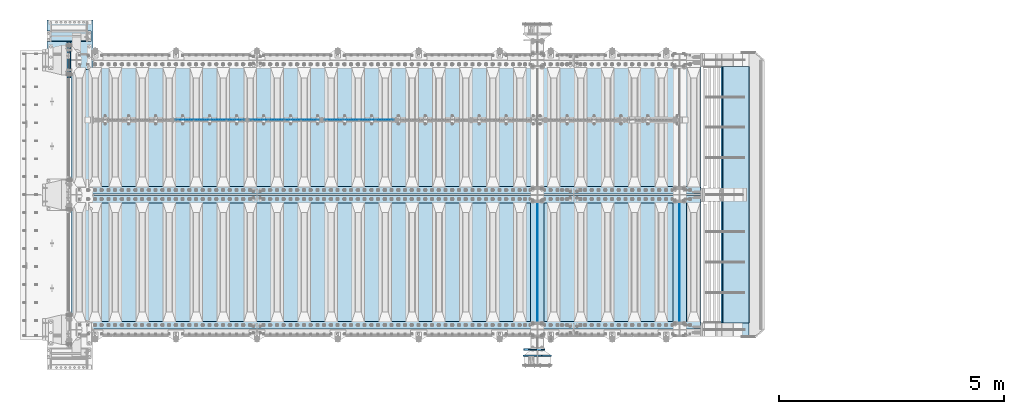
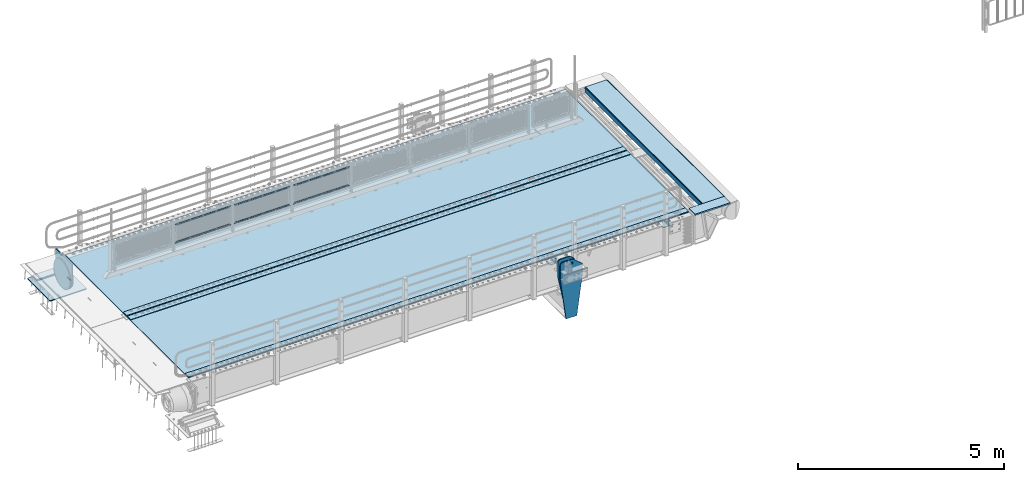
# One storey, part 152 of 193: 24 plates.
"""IFC2X3 building model written with IfcOpenShell, lengths in millimetres."""

from ifc_helpers import new_model, si_unit, frame, origin_with_axes, place, context, subcontext, project, spatial, faceted_brep, material, type_object, element, save


model = new_model("IFC2X3")

# Units and contexts
model_context = context("Model", 3, precision=1e-05, world=origin_with_axes())
body_context = subcontext(model_context, "Body", "Model", "MODEL_VIEW")
ifc_project = project(units=[si_unit("LENGTHUNIT", "METRE", prefix="MILLI"), si_unit("AREAUNIT", "SQUARE_METRE"), si_unit("VOLUMEUNIT", "CUBIC_METRE"), si_unit("MASSUNIT", "GRAM", prefix="KILO"), si_unit("TIMEUNIT", "SECOND"), si_unit("PLANEANGLEUNIT", "RADIAN"), si_unit("SOLIDANGLEUNIT", "STERADIAN"), si_unit("THERMODYNAMICTEMPERATUREUNIT", "DEGREE_CELSIUS"), si_unit("LUMINOUSINTENSITYUNIT", "LUMEN")], contexts=[model_context])

# Site, building, storey
site_placement = place(None, origin_with_axes())
site = spatial("IfcSite", under=ifc_project, at=site_placement, CompositionType="ELEMENT")
building_placement = place(site_placement, origin_with_axes())
building = spatial("IfcBuilding", under=site, at=building_placement, Name="Standard", CompositionType="ELEMENT")
storey_placement = place(building_placement, origin_with_axes())
storey = spatial("IfcBuildingStorey", under=building, at=storey_placement, Name="Undefined", CompositionType="ELEMENT", Elevation=0.0)

# Plates
ifc_material_1 = material(Name="STEEL/S355N")
plate_type_1 = type_object("IfcPlateType", PredefinedType="NOTDEFINED")
plate_1_placement = place(storey_placement, frame((-31899.9999999193, 23559.9999999953, -945.000018212691), z_axis=(-0.901283188008789, 0.0, 0.433230441004224), x_axis=(-0.433230441004221, 0.0, -0.90128318800879)))
element("IfcPlate", 1, at=plate_1_placement, inside=storey, type_object=plate_type_1, material=ifc_material_1, context=body_context, shape_type="Brep", body=[
    faceted_brep([(22.094240398199, -15.0000000000109, 175.22583880938), (22.094240398199, 14.9999999999854, 175.22583880938), (270.848403445216, 15.0, 55.654235574897), (270.848403445216, -15.0, 55.654235574897), (15.5957837831356, -15.0000000000109, 161.706590989248), (15.5957837831356, 14.9999999999854, 161.706590989248), (264.349946032446, -15.0, 42.1349881382121), (264.349946032446, 15.0, 42.1349881382121), (244.096420288086, -15.0, 6.91215973347425e-11), (244.096420288086, 15.0, 6.91215973347425e-11), (0.0, -15.0, 0.0), (0.0, 15.0, 0.0), (-976.801818847653, -15.0, 469.530853271488), (-976.801818847653, 15.0, 469.530853271488), (-1005.61098604241, -15.0, 584.572481266798), (-1005.61098604241, 15.0, 584.572481266794), (-1008.62084772102, -15.0, 603.379189822288), (-1008.62084772102, 15.0, 603.379189822292), (-1008.34151554686, -14.9999999999964, 622.423179098525), (-1008.34151554686, 15.0000000000036, 622.423179098525), (-1004.78138982914, -15.0, 641.133500175365), (-1004.78138982914, 15.0, 641.133500175365), (-998.047132923919, -15.0, 658.949304871177), (-998.047132923919, 15.0, 658.949304871177), (-903.393050005916, -15.0, 855.865691431824), (-903.393050005918, 15.0, 855.865691431824), (-891.965949445463, -15.0, 873.34628110176), (-891.965949445461, 15.0, 873.346281101767), (-876.403907448048, -15.0, 887.273681838968), (-876.403907448048, 15.0, 887.273681838968), (-857.767451990536, -15.0, 896.698763822915), (-857.767451990536, 15.0, 896.698763822918), (-837.326627351673, -14.9999999999964, 900.979222969672), (-837.326627351673, 15.0000000000036, 900.979222969676), (-816.474442649767, -15.0, 899.823352915755), (-816.474442649764, 15.0, 899.823352915759), (-796.631940525467, -14.9999999999964, 893.309924335023), (-796.631940525465, 15.0000000000036, 893.309924335026), (-427.105804443356, -14.9999999999964, 715.685363769535), (-427.105804443354, 15.0000000000036, 715.685363769539), (138.633743286133, -15.0, 288.410614013668), (138.633743286133, 15.0, 288.410614013668), (291.101928710936, -15.0, 97.7892227172815), (291.101928710936, 15.0, 97.7892227172815), (-886.324025694375, -15.0000000000182, 572.182288694501), (-886.324025694375, 14.9999999999818, 572.182288694501), (-901.776420284152, 14.9999999999818, 569.989346058286), (-901.776420284152, -15.0000000000182, 569.989346058286), (-872.8870774196, -15.0000000000182, 580.121678911954), (-872.8870774196, 14.9999999999818, 580.121678911954), (-863.511229028423, -15.0000000000182, 592.598816520771), (-863.511229028423, 14.9999999999818, 592.598816520771), (-859.623868446119, -15.0000000000182, 607.714170425563), (-859.623868446119, 14.9999999999818, 607.714170425563), (-861.816811082334, -15.0000000000182, 623.166565015341), (-861.816811082334, 14.9999999999818, 623.166565015341), (-869.756201299781, -15.0000000000182, 636.603513290116), (-869.756201299781, 14.9999999999818, 636.603513290116), (-882.233338908603, -15.0000000000182, 645.979361681293), (-882.233338908603, 14.9999999999818, 645.979361681293), (-897.348692813393, -15.0000000000182, 649.8667222636), (-897.348692813393, 14.9999999999818, 649.8667222636), (-912.80108740317, -15.0000000000182, 647.673779627385), (-912.80108740317, 14.9999999999818, 647.673779627385), (-926.238035677947, -15.0000000000182, 639.734389409932), (-926.238035677947, 14.9999999999818, 639.734389409932), (-935.613884069126, -15.0000000000182, 627.257251801111), (-935.613884069126, 14.9999999999818, 627.257251801111), (-939.501244651428, -15.0000000000182, 612.141897896323), (-939.501244651428, 14.9999999999818, 612.141897896323), (-937.308302015212, -15.0000000000182, 596.689503306545), (-937.308302015212, 14.9999999999818, 596.689503306545), (-929.368911797765, -15.0000000000182, 583.25255503177), (-929.368911797765, 14.9999999999818, 583.25255503177), (-916.891774188942, -15.0000000000182, 573.876706640593), (-916.891774188942, 14.9999999999818, 573.876706640593), (-844.133640442278, 15.0, 583.284362107021), (-843.85829752604, 15.0, 588.251621237385), (-847.175983297808, 15.0, 591.958700695603), (-852.143242428174, 15.0, 592.234043611839), (-855.850321886393, 15.0, 588.916357840073), (-856.125664802632, 15.0, 583.949098709705), (-852.807979030862, 15.0, 580.242019251487), (-847.840719900496, 15.0, 579.966676335251), (-847.840719900496, -15.0, 579.966676335251), (-852.807979030862, -15.0, 580.242019251487), (-844.133640442278, -15.0, 583.284362107021), (-843.85829752604, -15.0, 588.251621237385), (-847.175983297808, -15.0, 591.958700695603), (-852.143242428174, -15.0, 592.234043611839), (-855.850321886393, -15.0, 588.916357840073), (-856.125664802632, -15.0, 583.949098709705)], [[[0, 1, 2, 3]], [[4, 5, 1, 0]], [[6, 7, 5, 4]], [[8, 9, 7, 6]], [[8, 10, 11, 9]], [[10, 12, 13, 11]], [[12, 14, 15, 13]], [[14, 16, 17, 15]], [[16, 18, 19, 17]], [[18, 20, 21, 19]], [[20, 22, 23, 21]], [[22, 24, 25, 23]], [[24, 26, 27, 25]], [[26, 28, 29, 27]], [[28, 30, 31, 29]], [[30, 32, 33, 31]], [[32, 34, 35, 33]], [[34, 36, 37, 35]], [[36, 38, 39, 37]], [[38, 40, 41, 39]], [[40, 42, 43, 41]], [[43, 42, 3, 2]], [[44, 45, 46, 47]], [[48, 49, 45, 44]], [[50, 51, 49, 48]], [[52, 53, 51, 50]], [[54, 55, 53, 52]], [[56, 57, 55, 54]], [[58, 59, 57, 56]], [[60, 61, 59, 58]], [[62, 63, 61, 60]], [[64, 65, 63, 62]], [[66, 67, 65, 64]], [[68, 69, 67, 66]], [[70, 71, 69, 68]], [[72, 73, 71, 70]], [[74, 75, 73, 72]], [[47, 46, 75, 74]], [[9, 11, 13, 15, 17, 19, 21, 23, 25, 27, 29, 31, 33, 35, 37, 39, 41, 43, 2, 1, 5, 7], [76, 77, 78, 79, 80, 81, 82, 83], [45, 49, 51, 53, 55, 57, 59, 61, 63, 65, 67, 69, 71, 73, 75, 46]], [[84, 83, 82, 85]], [[86, 76, 83, 84]], [[87, 77, 76, 86]], [[88, 78, 77, 87]], [[89, 79, 78, 88]], [[90, 80, 79, 89]], [[91, 81, 80, 90]], [[85, 82, 81, 91]], [[3, 42, 40, 38, 36, 34, 32, 30, 28, 26, 24, 22, 20, 18, 16, 14, 12, 10, 8, 6, 4, 0], [90, 89, 88, 87, 86, 84, 85, 91], [70, 68, 66, 64, 62, 60, 58, 56, 54, 52, 50, 48, 44, 47, 74, 72]]]),
])
plate_type_2 = type_object("IfcPlateType", PredefinedType="NOTDEFINED")
for number, where, z_axis, x_axis in (
    (2, (-28895.0, 26825.0, 0.0), (0.0, 0.0, -1.0), (0.0, -1.0, 0.0)),
    (3, (-32060.0, 26825.0, 0.0), (0.0, 0.0, -1.0), (0.0, -1.0, 0.0)),
):
    element("IfcPlate", number, at=place(storey_placement, frame(where, z_axis=z_axis, x_axis=x_axis)), inside=storey, type_object=plate_type_2, material=ifc_material_1, context=body_context, shape_type="Brep", body=[
        faceted_brep([(0.0, -5.0, 0.0), (0.0, -5.0, 336.0), (0.0, 5.0, 336.0), (0.0, 5.0, 0.0), (2650.0, -5.0, 336.0), (2650.0, 5.0, 336.0), (2650.0, -5.0, 0.0), (2650.0, 5.0, 0.0)], [[[0, 1, 2, 3]], [[1, 4, 5, 2]], [[4, 6, 7, 5]], [[6, 0, 3, 7]], [[5, 7, 3, 2]], [[6, 4, 1, 0]]]),
    ])
plate_type_3 = type_object("IfcPlateType", PredefinedType="NOTDEFINED")
for number, where, z_axis, x_axis in (
    (4, (-29045.0, 24175.0, -343.0), (0.0, 1.0, 0.0), (1.0, 0.0, 0.0)),
    (5, (-32210.0, 24175.0, -343.0), (0.0, 1.0, 0.0), (1.0, 0.0, 0.0)),
):
    element("IfcPlate", number, at=place(storey_placement, frame(where, z_axis=z_axis, x_axis=x_axis)), inside=storey, type_object=plate_type_3, material=ifc_material_1, context=body_context, shape_type="Brep", body=[
        faceted_brep([(0.0, -7.0, 0.0), (0.0, -7.0, 2650.0), (0.0, 7.0, 2650.0), (0.0, 7.0, 0.0), (300.0, -7.0, 2650.0), (300.0, 7.0, 2650.0), (300.0, -7.0, 0.0), (300.0, 7.0, 0.0)], [[[0, 1, 2, 3]], [[1, 4, 5, 2]], [[4, 6, 7, 5]], [[6, 0, 3, 7]], [[5, 7, 3, 2]], [[6, 4, 1, 0]]]),
    ])
ifc_material_2 = material(Name="Misc_Undefined")
plate_type_4 = type_object("IfcPlateType", PredefinedType="NOTDEFINED")
plate_2_placement = place(storey_placement, frame((-36801.4949882696, 28670.5, 351.520303374641), z_axis=(0.0, 0.0, 1.0), x_axis=(1.0, 0.0, 0.0)))
element("IfcPlate", 6, at=plate_2_placement, inside=storey, type_object=plate_type_4, material=ifc_material_2, context=body_context, shape_type="Brep", body=[
    faceted_brep([(0.0, -1.49999999999636, 3.63797880709171e-12), (35.0002975463831, -1.5, 34.9996948242187), (35.0002975463831, 1.5, 34.9996948242187), (0.0, 1.50000000000364, 7.27595761418343e-12), (1515.99035644531, -1.5, 34.9999923706054), (1515.99035644531, 1.5, 34.9999923706054), (1550.98999023437, -1.5, 4.43037606601138e-09), (1550.98999023437, 1.5, 4.43037606601138e-09)], [[[0, 1, 2, 3]], [[1, 4, 5, 2]], [[4, 6, 7, 5]], [[6, 0, 3, 7]], [[5, 7, 3, 2]], [[6, 4, 1, 0]]]),
])
plate_3_placement = place(storey_placement, frame((-35250.4999998124, 28670.5, 914.520000175701), z_axis=(-0.707103624179499, 0.0, 0.707109938179501), x_axis=(-0.707109938179501, 0.0, -0.707103624179499)))
element("IfcPlate", 7, at=plate_3_placement, inside=storey, type_object=plate_type_4, material=ifc_material_2, context=body_context, shape_type="Brep", body=[
    faceted_brep([(0.0, -1.49999999999636, 3.63797880709171e-12), (1096.7275390625, -1.5, 1096.7177734375), (1096.7275390625, 1.5, 1096.7177734375), (0.0, 1.50000000000364, 7.27595761418343e-12), (1096.72045898438, -1.5, 1047.21337890625), (1096.72045898438, 1.5, 1047.21337890625), (49.4976959228552, -1.5, -1.01863406598568e-10), (49.4976959228552, 1.5, -1.01863406598568e-10)], [[[0, 1, 2, 3]], [[1, 4, 5, 2]], [[4, 6, 7, 5]], [[6, 0, 3, 7]], [[5, 7, 3, 2]], [[6, 4, 1, 0]]]),
])
plate_4_placement = place(storey_placement, frame((-38459.4949882696, 28670.5, 351.520303374641), z_axis=(0.0, 0.0, 1.0), x_axis=(1.0, 0.0, 0.0)))
element("IfcPlate", 8, at=plate_4_placement, inside=storey, type_object=plate_type_4, material=ifc_material_2, context=body_context, shape_type="Brep", body=[
    faceted_brep([(0.0, -1.49999999999636, 3.63797880709171e-12), (35.0002975463831, -1.5, 34.9996948242187), (35.0002975463831, 1.5, 34.9996948242187), (0.0, 1.50000000000364, 7.27595761418343e-12), (1515.99035644531, -1.5, 34.9999923706054), (1515.99035644531, 1.5, 34.9999923706054), (1550.98999023437, -1.5, 4.43037606601138e-09), (1550.98999023437, 1.5, 4.43037606601138e-09)], [[[0, 1, 2, 3]], [[1, 4, 5, 2]], [[4, 6, 7, 5]], [[6, 0, 3, 7]], [[5, 7, 3, 2]], [[6, 4, 1, 0]]]),
])
plate_5_placement = place(storey_placement, frame((-36908.4999998124, 28670.5, 914.520000175701), z_axis=(-0.707103624179499, 0.0, 0.707109938179501), x_axis=(-0.707109938179501, 0.0, -0.707103624179499)))
element("IfcPlate", 9, at=plate_5_placement, inside=storey, type_object=plate_type_4, material=ifc_material_2, context=body_context, shape_type="Brep", body=[
    faceted_brep([(0.0, -1.49999999999636, 3.63797880709171e-12), (1096.7275390625, -1.5, 1096.7177734375), (1096.7275390625, 1.5, 1096.7177734375), (0.0, 1.50000000000364, 7.27595761418343e-12), (1096.72045898438, -1.5, 1047.21337890625), (1096.72045898438, 1.5, 1047.21337890625), (49.4976959228552, -1.5, -1.01863406598568e-10), (49.4976959228552, 1.5, -1.01863406598568e-10)], [[[0, 1, 2, 3]], [[1, 4, 5, 2]], [[4, 6, 7, 5]], [[6, 0, 3, 7]], [[5, 7, 3, 2]], [[6, 4, 1, 0]]]),
])
plate_6_placement = place(storey_placement, frame((-40117.4949882696, 28670.5, 351.520303374641), z_axis=(0.0, 0.0, 1.0), x_axis=(1.0, 0.0, 0.0)))
element("IfcPlate", 10, at=plate_6_placement, inside=storey, type_object=plate_type_4, material=ifc_material_2, context=body_context, shape_type="Brep", body=[
    faceted_brep([(0.0, -1.49999999999636, 3.63797880709171e-12), (35.0002975463831, -1.5, 34.9996948242187), (35.0002975463831, 1.5, 34.9996948242187), (0.0, 1.50000000000364, 7.27595761418343e-12), (1515.99035644531, -1.5, 34.9999923706054), (1515.99035644531, 1.5, 34.9999923706054), (1550.98999023437, -1.5, 4.43037606601138e-09), (1550.98999023437, 1.5, 4.43037606601138e-09)], [[[0, 1, 2, 3]], [[1, 4, 5, 2]], [[4, 6, 7, 5]], [[6, 0, 3, 7]], [[5, 7, 3, 2]], [[6, 4, 1, 0]]]),
])
plate_7_placement = place(storey_placement, frame((-38566.4999998124, 28670.5, 914.520000175701), z_axis=(-0.707103624179499, 0.0, 0.707109938179501), x_axis=(-0.707109938179501, 0.0, -0.707103624179499)))
element("IfcPlate", 11, at=plate_7_placement, inside=storey, type_object=plate_type_4, material=ifc_material_2, context=body_context, shape_type="Brep", body=[
    faceted_brep([(0.0, -1.49999999999636, 3.63797880709171e-12), (1096.7275390625, -1.5, 1096.7177734375), (1096.7275390625, 1.5, 1096.7177734375), (0.0, 1.50000000000364, 7.27595761418343e-12), (1096.72045898438, -1.5, 1047.21337890625), (1096.72045898438, 1.5, 1047.21337890625), (49.4976959228552, -1.5, -1.01863406598568e-10), (49.4976959228552, 1.5, -1.01863406598568e-10)], [[[0, 1, 2, 3]], [[1, 4, 5, 2]], [[4, 6, 7, 5]], [[6, 0, 3, 7]], [[5, 7, 3, 2]], [[6, 4, 1, 0]]]),
])
ifc_material_3 = material()
plate_type_5 = type_object("IfcPlateType", PredefinedType="NOTDEFINED")
plate_8_placement = place(storey_placement, frame((-41995.0, 30645.0, -803.000000000004), z_axis=(0.0, -1.0, 0.0), x_axis=(-1.0, 0.0, 0.0)))
element("IfcPlate", 12, at=plate_8_placement, inside=storey, type_object=plate_type_5, material=ifc_material_3, context=body_context, shape_type="Brep", body=[
    faceted_brep([(0.0, 0.0, 235.0), (0.0, -15.0, 220.0), (979.0, -15.0, 220.0), (979.0, 0.0, 235.0), (0.0, 15.0, 235.0), (0.0, 15.0, 0.0), (0.0, -15.0, 0.0), (979.0, 15.0, 235.0), (979.0, -15.0, 0.0), (979.0, 15.0, 0.0)], [[[0, 1, 2, 3]], [[4, 5, 6, 1, 0]], [[7, 4, 0, 3]], [[8, 9, 7, 3, 2]], [[8, 6, 5, 9]], [[7, 9, 5, 4]], [[6, 8, 2, 1]]]),
])
plate_type_6 = type_object("IfcPlateType", PredefinedType="NOTDEFINED")
plate_9_placement = place(storey_placement, frame((-42974.0, 30890.0, -1043.0), z_axis=(1.0, 0.0, 0.0), x_axis=(0.0, -1.0, 0.0)))
element("IfcPlate", 13, at=plate_9_placement, inside=storey, type_object=plate_type_6, material=ifc_material_3, context=body_context, shape_type="Brep", body=[
    faceted_brep([(0.0, -15.0, 0.0), (2.93249104288407e-06, -15.0, 1025.0), (2.93249104288407e-06, 15.0, 1025.0), (0.0, 15.0, 0.0), (1100.0, -15.0, 1025.0), (1100.0, 15.0, 1025.0), (1100.0, -15.0, -2.18278728425503e-11), (1100.0, 15.0, -2.18278728425503e-11)], [[[0, 1, 2, 3]], [[1, 4, 5, 2]], [[4, 6, 7, 5]], [[6, 0, 3, 7]], [[5, 7, 3, 2]], [[6, 4, 1, 0]]]),
])
plate_type_7 = type_object("IfcPlateType", PredefinedType="NOTDEFINED")
plate_10_placement = place(storey_placement, frame((-31909.9999999327, 23419.9999999953, -1470.00001820618), z_axis=(0.0, 0.0, 1.0), x_axis=(-1.0, 0.0, 0.0)))
element("IfcPlate", 14, at=plate_10_placement, inside=storey, type_object=plate_type_7, material=ifc_material_1, context=body_context, shape_type="Brep", body=[
    faceted_brep([(145.403805922699, -15.0, 1549.59619407771), (145.403805922699, 15.0, 1549.59619407771), (150.000000000411, 15.0, 1551.5), (150.000000000411, -15.0, 1551.5), (154.596194078124, 15.0, 1549.59619407771), (154.596194078124, -15.0, 1549.59619407771), (156.500000000411, 15.0, 1545.0), (156.500000000411, -15.0, 1545.0), (154.596194078124, 15.0, 1540.40380592229), (154.596194078124, -15.0, 1540.40380592229), (150.000000000411, 15.0, 1538.5), (150.000000000411, -15.0, 1538.5), (145.403805922699, 15.0, 1540.40380592229), (145.403805922699, -15.0, 1540.40380592229), (143.500000000411, 15.0, 1545.0), (143.500000000411, -15.0, 1545.0), (300.0, -15.0, 0.0), (0.0, -15.0, 0.0), (0.0, 15.0, 0.0), (300.0, 15.0, 0.0), (462.5, -15.0, 1210.0), (462.5, 15.0, 1210.0), (462.5, -15.0, 1630.0), (462.5, 15.0, 1630.0), (459.774066103124, -15.0, 1650.7055236082), (459.774066103124, 15.0, 1650.7055236082), (451.782032302755, -15.0, 1670.0), (451.782032302755, 15.0, 1670.0), (439.068542494922, -15.0, 1686.56854249492), (439.068542494922, 15.0, 1686.56854249492), (422.5, -15.0, 1699.28203230276), (422.5, 15.0, 1699.28203230276), (403.205523608201, -15.0, 1707.27406610313), (403.205523608201, 15.0, 1707.27406610313), (382.5, -15.0, 1710.0), (382.5, 15.0, 1710.0), (151.788081037081, -15.0, 1710.0), (151.788081037081, 15.0, 1710.0), (132.694887325029, -15.0, 1708.33028179541), (132.694887325029, 15.0, 1708.33028179541), (114.181334578883, -15.0, 1703.37181734316), (114.181334578883, 15.0, 1703.37181734316), (96.809466726856, -15.0, 1695.27513824985), (96.809466726856, 15.0, 1695.27513824985), (81.1066678416755, -15.0, 1684.28604765144), (81.1066678416755, 15.0, 1684.28604765144), (-162.5, -15.0, 1480.0), (-162.5, 15.0, 1480.0), (-162.5, -15.0, 1210.0), (-162.5, 15.0, 1210.0), (121.715728752948, -15.0, 1628.28427124746), (134.692662705809, -15.0, 1636.95518130045), (150.000000000411, -15.0, 1640.0), (165.307337295013, -15.0, 1636.95518130045), (178.284271247874, -15.0, 1628.28427124746), (186.955181300862, -15.0, 1615.3073372946), (190.000000000411, -15.0, 1600.0), (186.955181300862, -15.0, 1584.6926627054), (178.284271247874, -15.0, 1571.71572875254), (165.307337295013, -15.0, 1563.04481869955), (150.000000000411, -15.0, 1560.0), (134.692662705809, -15.0, 1563.04481869955), (121.715728752948, -15.0, 1571.71572875254), (113.04481869996, -15.0, 1584.6926627054), (110.000000000411, -15.0, 1600.0), (113.04481869996, -15.0, 1615.3073372946), (121.715728752948, 14.9999999999527, 1571.71572875254), (113.04481869996, 14.9999999999527, 1584.6926627054), (134.692662705809, 14.9999999999527, 1563.04481869955), (150.000000000411, 14.9999999999527, 1560.0), (165.307337295013, 14.9999999999527, 1563.04481869955), (178.284271247874, 14.9999999999527, 1571.71572875254), (186.955181300862, 14.9999999999527, 1584.6926627054), (190.000000000411, 14.9999999999527, 1600.0), (186.955181300862, 14.9999999999527, 1615.3073372946), (178.284271247874, 14.9999999999527, 1628.28427124746), (165.307337295013, 14.9999999999527, 1636.95518130045), (150.000000000411, 14.9999999999527, 1640.0), (134.692662705809, 14.9999999999527, 1636.95518130045), (121.715728752948, 14.9999999999527, 1628.28427124746), (113.04481869996, 14.9999999999527, 1615.3073372946), (110.000000000411, 14.9999999999527, 1600.0)], [[[0, 1, 2, 3]], [[3, 2, 4, 5]], [[5, 4, 6, 7]], [[7, 6, 8, 9]], [[9, 8, 10, 11]], [[11, 10, 12, 13]], [[13, 12, 14, 15]], [[15, 14, 1, 0]], [[16, 17, 18, 19]], [[20, 16, 19, 21]], [[22, 20, 21, 23]], [[24, 22, 23, 25]], [[26, 24, 25, 27]], [[28, 26, 27, 29]], [[30, 28, 29, 31]], [[32, 30, 31, 33]], [[34, 32, 33, 35]], [[36, 34, 35, 37]], [[38, 36, 37, 39]], [[40, 38, 39, 41]], [[42, 40, 41, 43]], [[44, 42, 43, 45]], [[46, 44, 45, 47]], [[48, 46, 47, 49]], [[17, 48, 49, 18]], [[16, 20, 22, 24, 26, 28, 30, 32, 34, 36, 38, 40, 42, 44, 46, 48, 17], [3, 5, 7, 9, 11, 13, 15, 0], [50, 51, 52, 53, 54, 55, 56, 57, 58, 59, 60, 61, 62, 63, 64, 65]], [[62, 66, 67, 63]], [[61, 68, 66, 62]], [[60, 69, 68, 61]], [[59, 70, 69, 60]], [[58, 71, 70, 59]], [[57, 72, 71, 58]], [[56, 73, 72, 57]], [[55, 74, 73, 56]], [[54, 75, 74, 55]], [[53, 76, 75, 54]], [[52, 77, 76, 53]], [[51, 78, 77, 52]], [[50, 79, 78, 51]], [[65, 80, 79, 50]], [[64, 81, 80, 65]], [[63, 67, 81, 64]], [[47, 45, 43, 41, 39, 37, 35, 33, 31, 29, 27, 25, 23, 21, 19, 18, 49], [10, 8, 6, 4, 2, 1, 14, 12], [66, 68, 69, 70, 71, 72, 73, 74, 75, 76, 77, 78, 79, 80, 81, 67]]]),
])
ifc_material_4 = material(Name="STEEL/S235JR")
plate_type_8 = type_object("IfcPlateType", PredefinedType="NOTDEFINED")
for number, where, z_axis, x_axis in (
    (15, (-28433.0, 27015.0, 20.0), (-1.0, 0.0, 0.0), (0.0, 1.0, 0.0)),
    (16, (-28433.0, 26815.0, 20.0), (-1.0, 0.0, 0.0), (0.0, 1.0, 0.0)),
    (17, (-28433.0, 24015.0, 20.0), (-1.0, 0.0, 0.0), (0.0, 1.0, 0.0)),
):
    element("IfcPlate", number, at=place(storey_placement, frame(where, z_axis=z_axis, x_axis=x_axis)), inside=storey, type_object=plate_type_8, material=ifc_material_4, context=body_context, shape_type="Brep", body=[
        faceted_brep([(0.0, -6.0, 0.0), (0.0, -6.0, 13997.0), (0.0, 6.0, 13997.0), (0.0, 6.0, 0.0), (170.0, -6.0, 13997.0), (170.0, 6.0, 13997.0), (170.0, -6.0, 0.0), (170.0, 6.0, 0.0)], [[[0, 1, 2, 3]], [[1, 4, 5, 2]], [[4, 6, 7, 5]], [[6, 0, 3, 7]], [[5, 7, 3, 2]], [[6, 4, 1, 0]]]),
    ])
plate_type_9 = type_object("IfcPlateType", PredefinedType="NOTDEFINED")
for number, where, z_axis, x_axis in (
    (18, (-42440.0, 29995.0, 7.0), (1.0, 0.0, 0.0), (0.0, -1.0, 0.0)),
    (19, (-42440.0, 26995.0, 7.0), (1.0, 0.0, 0.0), (0.0, -1.0, 0.0)),
):
    element("IfcPlate", number, at=place(storey_placement, frame(where, z_axis=z_axis, x_axis=x_axis)), inside=storey, type_object=plate_type_9, material=ifc_material_1, context=body_context, shape_type="Brep", body=[
        faceted_brep([(0.0, -7.0, 0.0), (-2.96859070658684e-09, -7.0, 14017.0), (-2.96859070658684e-09, 7.0, 14017.0), (0.0, 7.0, 0.0), (2990.0, -7.0, 14017.0), (2990.0, 7.0, 14017.0), (2990.0, -7.0, 0.0), (2990.0, 7.0, 0.0)], [[[0, 1, 2, 3]], [[1, 4, 5, 2]], [[4, 6, 7, 5]], [[6, 0, 3, 7]], [[5, 7, 3, 2]], [[6, 4, 1, 0]]]),
    ])
plate_type_10 = type_object("IfcPlateType", PredefinedType="NOTDEFINED")
plate_11_placement = place(storey_placement, frame((-42512.5, 30400.0, -114.999999999998), z_axis=(0.0, 0.0, -1.0), x_axis=(0.0, -1.0, 0.0)))
element("IfcPlate", 20, at=plate_11_placement, inside=storey, type_object=plate_type_10, material=ifc_material_1, context=body_context, shape_type="Brep", body=[
    faceted_brep([(0.0, -12.5, 400.0), (2.91645036198679, -12.5, 448.214672101512), (2.91645036198679, 12.5, 448.214672101512), (0.0, 12.5, 400.0), (11.6232730309493, -12.5, 495.726265714256), (11.6232730309493, 12.5, 495.726265714256), (25.9935029273365, -12.5, 541.8419548161), (25.9935029273365, 12.5, 541.8419548161), (45.8175897403271, -12.5, 585.889268816449), (45.8175897403271, 12.5, 585.889268816449), (70.8064536442362, -12.5, 627.225898691268), (70.8064536442362, 12.5, 627.225898691268), (100.595700733313, -12.5, 665.249063294999), (100.595700733313, 12.5, 665.249063294999), (134.75093670547, -12.5, 699.404299267018), (134.75093670547, 12.5, 699.404299267018), (172.774101309333, -12.5, 729.193546355957), (172.774101309333, 12.5, 729.193546355957), (214.110731184279, -12.5, 754.182410259709), (214.110731184279, 12.5, 754.182410259709), (258.15804518474, -12.5, 774.006497072558), (258.15804518474, 12.5, 774.006497072558), (304.273734286686, -12.5, 788.3767269688), (304.273734286686, 12.5, 788.3767269688), (351.785327899521, -12.5, 797.08354963762), (351.785327899521, 12.5, 797.08354963762), (400.0, -12.5, 800.0), (400.0, 12.5, 800.0), (448.214672103386, -12.5, 797.083549638417), (448.214672103386, 12.5, 797.083549638417), (495.726265716061, -12.5, 788.376726969676), (495.726265716061, 12.5, 788.376726969676), (541.841954817824, -12.5, 774.006497073486), (541.841954817824, 12.5, 774.006497073486), (585.889268818086, -12.5, 754.182410260677), (585.889268818086, 12.5, 754.182410260677), (627.225898692806, -12.5, 729.193546356939), (627.225898692806, 12.5, 729.193546356939), (665.249063296429, -12.5, 699.404299268001), (665.249063296429, 12.5, 699.404299268001), (699.404299268313, -12.5, 665.249063295971), (699.404299268313, 12.5, 665.249063295971), (729.193546357106, -12.5, 627.225898692217), (729.193546357106, 12.5, 627.225898692217), (754.182410260699, -12.5, 585.889268817373), (754.182410260699, 12.5, 585.889268817373), (774.006497073362, -12.5, 541.841954816995), (774.006497073362, 12.5, 541.841954816995), (788.376726969407, -12.5, 495.72626571513), (788.376726969407, 12.5, 495.72626571513), (797.083549638006, -12.5, 448.214672102371), (797.083549638006, 12.5, 448.214672102371), (800.0, -12.5, 400.0), (800.0, 12.5, 400.0), (797.08354963802, -12.5, 351.785327898502), (797.08354963802, 12.5, 351.785327898502), (788.376726969058, -12.5, 304.273734285758), (788.376726969058, 12.5, 304.273734285758), (774.006497072671, -12.5, 258.158045183915), (774.006497072671, 12.5, 258.158045183915), (754.182410259677, -12.5, 214.110731183569), (754.182410259677, 12.5, 214.110731183569), (729.193546355775, -12.5, 172.774101308751), (729.193546355775, 12.5, 172.774101308751), (699.404299266695, -12.5, 134.750936705022), (699.404299266695, 12.5, 134.750936705022), (665.249063294537, -12.5, 100.595700733003), (665.249063294537, 12.5, 100.595700733003), (627.225898690671, -12.5, 70.8064536440688), (627.225898690671, 12.5, 70.8064536440688), (585.889268815728, -12.5, 45.8175897403125), (585.889268815728, 12.5, 45.8175897403125), (541.841954815267, -12.5, 25.9935029274711), (541.841954815267, 12.5, 25.9935029274711), (495.726265713321, -12.5, 11.6232730312295), (495.726265713321, 12.5, 11.6232730312295), (448.214672100487, -12.5, 2.9164503624088), (448.214672100487, 12.5, 2.9164503624088), (400.0, -12.5, -5.6843418860808e-14), (400.0, 12.5, -5.6843418860808e-14), (351.785327896621, -12.5, 2.91645036159025), (351.785327896621, 12.5, 2.91645036159025), (304.27373428395, -12.5, 11.6232730303345), (304.27373428395, 12.5, 11.6232730303345), (258.158045182186, -12.5, 25.9935029265253), (258.158045182186, 12.5, 25.9935029265253), (214.110731181921, -12.5, 45.8175897393376), (214.110731181921, 12.5, 45.8175897393376), (172.774101307201, -12.5, 70.8064536430757), (172.774101307201, 12.5, 70.8064536430757), (134.750936703582, -12.5, 100.59570073201), (134.750936703582, 12.5, 100.59570073201), (100.595700731694, -12.5, 134.750936704037), (100.595700731694, 12.5, 134.750936704037), (70.8064536429047, -12.5, 172.774101307794), (70.8064536429047, 12.5, 172.774101307794), (45.8175897393085, -12.5, 214.110731182634), (45.8175897393085, 12.5, 214.110731182634), (25.9935029266453, -12.5, 258.158045183012), (25.9935029266453, 12.5, 258.158045183012), (11.6232730306001, -12.5, 304.273734284878), (11.6232730306001, 12.5, 304.273734284878), (2.9164503619977, -12.5, 351.78532789764), (2.9164503619977, 12.5, 351.78532789764)], [[[0, 1, 2, 3]], [[1, 4, 5, 2]], [[4, 6, 7, 5]], [[6, 8, 9, 7]], [[8, 10, 11, 9]], [[10, 12, 13, 11]], [[12, 14, 15, 13]], [[14, 16, 17, 15]], [[16, 18, 19, 17]], [[18, 20, 21, 19]], [[20, 22, 23, 21]], [[22, 24, 25, 23]], [[24, 26, 27, 25]], [[26, 28, 29, 27]], [[28, 30, 31, 29]], [[30, 32, 33, 31]], [[32, 34, 35, 33]], [[34, 36, 37, 35]], [[36, 38, 39, 37]], [[38, 40, 41, 39]], [[40, 42, 43, 41]], [[42, 44, 45, 43]], [[44, 46, 47, 45]], [[46, 48, 49, 47]], [[48, 50, 51, 49]], [[50, 52, 53, 51]], [[52, 54, 55, 53]], [[54, 56, 57, 55]], [[56, 58, 59, 57]], [[58, 60, 61, 59]], [[60, 62, 63, 61]], [[62, 64, 65, 63]], [[64, 66, 67, 65]], [[66, 68, 69, 67]], [[68, 70, 71, 69]], [[70, 72, 73, 71]], [[72, 74, 75, 73]], [[74, 76, 77, 75]], [[76, 78, 79, 77]], [[78, 80, 81, 79]], [[80, 82, 83, 81]], [[82, 84, 85, 83]], [[84, 86, 87, 85]], [[86, 88, 89, 87]], [[88, 90, 91, 89]], [[90, 92, 93, 91]], [[92, 94, 95, 93]], [[94, 96, 97, 95]], [[96, 98, 99, 97]], [[98, 100, 101, 99]], [[100, 102, 103, 101]], [[102, 0, 3, 103]], [[5, 7, 9, 11, 13, 15, 17, 19, 21, 23, 25, 27, 29, 31, 33, 35, 37, 39, 41, 43, 45, 47, 49, 51, 53, 55, 57, 59, 61, 63, 65, 67, 69, 71, 73, 75, 77, 79, 81, 83, 85, 87, 89, 91, 93, 95, 97, 99, 101, 103, 3, 2]], [[102, 100, 98, 96, 94, 92, 90, 88, 86, 84, 82, 80, 78, 76, 74, 72, 70, 68, 66, 64, 62, 60, 58, 56, 54, 52, 50, 48, 46, 44, 42, 40, 38, 36, 34, 32, 30, 28, 26, 24, 22, 20, 18, 16, 14, 12, 10, 8, 6, 4, 1, 0]]]),
])
plate_type_11 = type_object("IfcPlateType", PredefinedType="NOTDEFINED")
plate_12_placement = place(storey_placement, frame((-42455.0, 29600.0, -20.0), z_axis=(0.0, 1.0, 0.0), x_axis=(0.0, 0.0, -1.0)))
element("IfcPlate", 21, at=plate_12_placement, inside=storey, type_object=plate_type_11, material=ifc_material_1, context=body_context, shape_type="Brep", body=[
    faceted_brep([(855.0, -15.0, 572.963114671471), (855.0, 15.0, 572.963114671471), (849.182410261268, 15.0, 585.889268817518), (849.182410261268, -15.0, 585.889268817518), (824.19354635745, 15.0, 627.225898692468), (824.19354635745, -15.0, 627.225898692468), (794.404299268433, 15.0, 665.249063296324), (794.404299268433, -15.0, 665.249063296324), (760.249063296315, 15.0, 699.404299268441), (760.249063296315, -15.0, 699.404299268441), (722.225898692465, 15.0, 729.193546357463), (722.225898692465, -15.0, 729.193546357463), (680.889268817516, 15.0, 754.182410261281), (680.889268817516, -15.0, 754.182410261281), (636.841954817028, 15.0, 774.006497074162), (636.841954817028, -15.0, 774.006497074162), (590.726265715042, 15.0, 788.376726970419), (590.726265715042, -15.0, 788.376726970419), (543.214672102154, 15.0, 797.083549639221), (543.214672102154, -15.0, 797.083549639221), (495.0, -15.0, 800.000000000029), (495.0, 15.0, 800.0), (494.999999999412, -15.0, 0.0), (494.999999999412, 15.0, 0.0), (543.214672102129, 15.0, 2.91645036080809), (543.214672102129, -15.0, 2.91645036080809), (590.726265715023, 15.0, 11.6232730296069), (590.726265715023, -15.0, 11.6232730296069), (636.841954817014, 15.0, 25.9935029258631), (636.841954817014, -15.0, 25.9935029258631), (680.889268817507, 15.0, 45.8175897387446), (680.889268817507, -15.0, 45.8175897387446), (722.225898692462, 15.0, 70.8064536425663), (722.225898692462, -15.0, 70.8064536425663), (760.249063296318, 15.0, 100.595700731588), (760.249063296318, -15.0, 100.595700731588), (794.404299268441, 15.0, 134.750936703713), (794.404299268441, -15.0, 134.750936703713), (824.193546357463, 15.0, 172.774101307568), (824.193546357463, -15.0, 172.774101307568), (849.182410261284, 15.0, 214.110731182522), (849.182410261284, -15.0, 214.110731182522), (855.0, -15.0, 227.036885328536), (855.0, 15.0, 227.036885328536), (0.0, -15.0, 0.0), (0.0, 15.0, 0.0), (0.0, 15.0, 800.0), (0.0, -15.0, 800.0)], [[[0, 1, 2, 3]], [[3, 2, 4, 5]], [[5, 4, 6, 7]], [[7, 6, 8, 9]], [[9, 8, 10, 11]], [[11, 10, 12, 13]], [[13, 12, 14, 15]], [[15, 14, 16, 17]], [[17, 16, 18, 19]], [[20, 19, 18, 21]], [[22, 23, 24, 25]], [[25, 24, 26, 27]], [[27, 26, 28, 29]], [[29, 28, 30, 31]], [[31, 30, 32, 33]], [[33, 32, 34, 35]], [[35, 34, 36, 37]], [[37, 36, 38, 39]], [[39, 38, 40, 41]], [[42, 41, 40, 43]], [[42, 43, 1, 0]], [[44, 45, 23, 22]], [[16, 14, 12, 10, 8, 6, 4, 2, 1, 43, 40, 38, 36, 34, 32, 30, 28, 26, 24, 23, 45, 46, 21, 18]], [[44, 47, 46, 45]], [[46, 47, 20, 21]], [[47, 44, 22, 25, 27, 29, 31, 33, 35, 37, 39, 41, 42, 0, 3, 5, 7, 9, 11, 13, 15, 17, 19, 20]]]),
])
plate_type_12 = type_object("IfcPlateType", PredefinedType="NOTDEFINED")
plate_13_placement = place(storey_placement, frame((-28343.0011701094, 24150.0, -10.0000000001684), z_axis=(1.0, 0.0, 0.0), x_axis=(0.0, -1.0, 0.0)))
element("IfcPlate", 22, at=plate_13_placement, inside=storey, type_object=plate_type_12, material=ifc_material_1, context=body_context, shape_type="Brep", body=[
    faceted_brep([(300.0, 7.0, 986.0), (300.0, 20.0, 956.0), (-3.63797880709171e-11, 20.0, 956.0), (-3.63797880709171e-11, 7.0, 986.0), (0.0, 20.0, 0.0), (0.0, -20.0, 0.0), (-3.63797880709171e-11, -20.0, 986.0), (300.0, -20.0, 986.0), (300.0, -20.0, 0.0), (300.0, 20.0, 0.0)], [[[0, 1, 2, 3]], [[4, 5, 6, 3, 2]], [[6, 7, 0, 3]], [[7, 8, 9, 1, 0]], [[8, 5, 4, 9]], [[9, 4, 2, 1]], [[8, 7, 6, 5]]]),
])
plate_type_13 = type_object("IfcPlateType", PredefinedType="NOTDEFINED")
plate_14_placement = place(storey_placement, frame((-27949.4454489358, 29850.0000000016, -155.274111776635), z_axis=(0.0, -1.0, 0.0), x_axis=(-0.0871556999853766, 0.0, 0.99619470183296)))
element("IfcPlate", 23, at=plate_14_placement, inside=storey, type_object=plate_type_13, material=ifc_material_1, context=body_context, shape_type="Brep", body=[
    faceted_brep([(0.0, -10.0, 0.0), (4.54747350886464e-13, -9.99999999999272, 5700.0), (-4.54747350886464e-13, 10.0000000000036, 5700.0), (0.0, 10.0, 0.0), (155.0, -9.99999999999272, 5700.0), (155.0, 10.0000000000036, 5700.0), (155.0, -9.99999999999272, 0.0), (155.0, 10.0000000000036, 0.0)], [[[0, 1, 2, 3]], [[1, 4, 5, 2]], [[4, 6, 7, 5]], [[6, 0, 3, 7]], [[5, 7, 3, 2]], [[6, 4, 1, 0]]]),
])
plate_type_14 = type_object("IfcPlateType", PredefinedType="NOTDEFINED")
plate_15_placement = place(storey_placement, frame((-27952.997031974, 29850.0000000016, 0.00398537333359705), z_axis=(0.999999999979944, 6.49000001417961e-07, -6.29999999987365e-06), x_axis=(0.0, -1.0, 0.0)))
element("IfcPlate", 24, at=plate_15_placement, inside=storey, type_object=plate_type_14, material=ifc_material_1, context=body_context, shape_type="Brep", body=[
    faceted_brep([(5700.00047245355, -10.0, 596.995666503906), (5700.00048828125, 5.77066172624541e-13, 616.995666503906), (0.000205282329261536, 5.75844927297453e-13, 616.995788574219), (0.000198628073121654, -10.0, 596.995788574219), (0.000205282329261536, 10.0, 616.995788574219), (0.0, 10.0, 0.0), (0.0, -10.0, 0.0), (5700.00048828125, 10.0, 616.995666503906), (5700.0, -10.0, -7.64703145250678e-09), (5700.0, 10.0, -7.64339347369969e-09)], [[[0, 1, 2, 3]], [[4, 5, 6, 3, 2]], [[7, 4, 2, 1]], [[8, 9, 7, 1, 0]], [[8, 6, 5, 9]], [[7, 9, 5, 4]], [[6, 8, 0, 3]]]),
])

save(model, "model.ifc")
